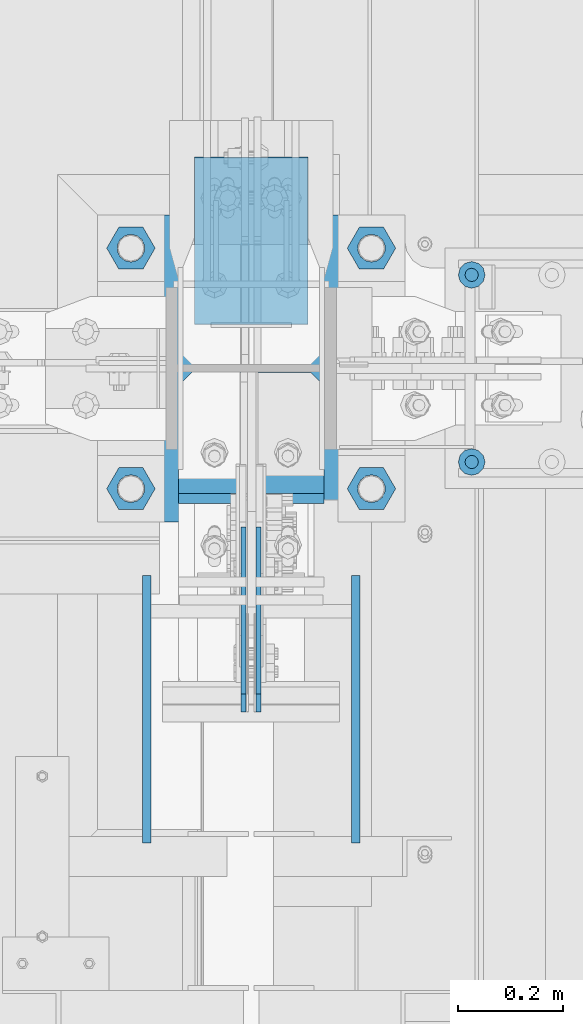
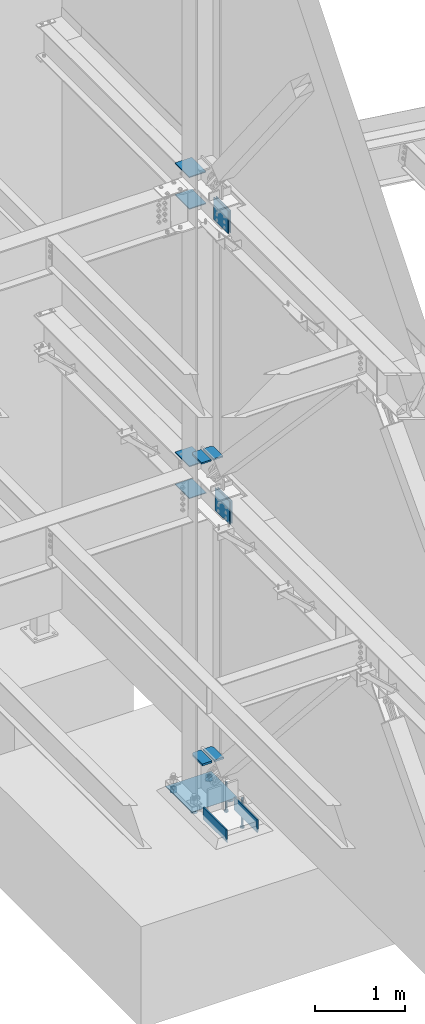
# One storey, part 897 of 1179: 21 beams, 11 elements without a shape of their own.
"""IFC2X3 building model written with IfcOpenShell, lengths in millimetres."""

from ifc_helpers import new_model, si_unit, frame, origin_with_axes, place, context, subcontext, project, spatial, faceted_brep, material, type_object, element, aggregate, save


model = new_model("IFC2X3")

# Units and contexts
model_context = context("Model", 3, precision=1e-05, world=origin_with_axes())
body_context = subcontext(model_context, "Body", "Model", "MODEL_VIEW")
ifc_project = project(units=[si_unit("LENGTHUNIT", "METRE", prefix="MILLI"), si_unit("AREAUNIT", "SQUARE_METRE"), si_unit("VOLUMEUNIT", "CUBIC_METRE"), si_unit("MASSUNIT", "GRAM", prefix="KILO"), si_unit("TIMEUNIT", "SECOND"), si_unit("PLANEANGLEUNIT", "RADIAN"), si_unit("SOLIDANGLEUNIT", "STERADIAN"), si_unit("THERMODYNAMICTEMPERATUREUNIT", "DEGREE_CELSIUS"), si_unit("LUMINOUSINTENSITYUNIT", "LUMEN")], contexts=[model_context])

# Site, building, storey
site_placement = place(None, origin_with_axes())
site = spatial("IfcSite", under=ifc_project, at=site_placement, CompositionType="ELEMENT")
building_placement = place(site_placement, origin_with_axes())
building = spatial("IfcBuilding", under=site, at=building_placement, Name="Undefined", CompositionType="ELEMENT")
storey_placement = place(building_placement, origin_with_axes())
storey = spatial("IfcBuildingStorey", under=building, at=storey_placement, Name="Undefined", CompositionType="ELEMENT", Elevation=0.0)

# Assembly, beams
assembly_1_placement = place(storey_placement, origin_with_axes())
assembly_1 = element("IfcElementAssembly", 1, at=assembly_1_placement, inside=storey, Name="COLUMN", AssemblyPlace="NOTDEFINED", PredefinedType="RIGID_FRAME")
ifc_material_1 = material(Name="STEEL/A572-GR.50")
beam_type_1 = type_object("IfcBeamType", PredefinedType="NOTDEFINED")
beam_1_placement = place(assembly_1_placement, frame((24307.8, 34475.7375, 7591.425), z_axis=(1.0, 0.0, 0.0), x_axis=(0.0, 1.0, 0.0)))
beam_1 = element("IfcBeam", 2, at=beam_1_placement, type_object=beam_type_1, material=ifc_material_1, Name="PLATE", context=body_context, shape_type="Brep", body=[
    faceted_brep([(0.0, 6.35000000000036, -107.949999999997), (0.0, 6.35000000000036, 107.949999999997), (317.5, 6.35000000000036, 107.949999999997), (317.5, 6.35000000000036, -107.949999999997), (0.0, -6.35000000000036, 107.949999999997), (317.5, -6.35000000000036, 107.949999999997), (0.0, -6.35000000000036, -107.949999999997), (317.5, -6.35000000000036, -107.949999999997)], [[[0, 1, 2, 3]], [[1, 4, 5, 2]], [[4, 6, 7, 5]], [[6, 0, 3, 7]], [[5, 7, 3, 2]], [[6, 4, 1, 0]]]),
])
beam_2_placement = place(assembly_1_placement, frame((24307.8, 34475.7375, 8020.05), z_axis=(1.0, 0.0, 0.0), x_axis=(0.0, 1.0, 0.0)))
beam_2 = element("IfcBeam", 3, at=beam_2_placement, type_object=beam_type_1, material=ifc_material_1, Name="PLATE", context=body_context, shape_type="Brep", body=[
    faceted_brep([(0.0, 6.35000000000036, -107.949999999997), (0.0, 6.35000000000036, 107.949999999997), (317.5, 6.35000000000036, 107.949999999997), (317.5, 6.35000000000036, -107.949999999997), (0.0, -6.35000000000036, 107.949999999997), (317.5, -6.35000000000036, 107.949999999997), (0.0, -6.35000000000036, -107.949999999997), (317.5, -6.35000000000036, -107.949999999997)], [[[0, 1, 2, 3]], [[1, 4, 5, 2]], [[4, 6, 7, 5]], [[6, 0, 3, 7]], [[5, 7, 3, 2]], [[6, 4, 1, 0]]]),
])
beam_3_placement = place(assembly_1_placement, frame((24307.8, 34474.94375, 3676.65), z_axis=(1.0, 0.0, 0.0), x_axis=(0.0, 1.0, 0.0)))
beam_3 = element("IfcBeam", 4, at=beam_3_placement, type_object=beam_type_1, material=ifc_material_1, Name="PLATE", context=body_context, shape_type="Brep", body=[
    faceted_brep([(0.0, 6.35000000000036, -107.949999999997), (0.0, 6.35000000000036, 107.949999999997), (317.5, 6.35000000000036, 107.949999999997), (317.5, 6.35000000000036, -107.949999999997), (0.0, -6.35000000000036, 107.949999999997), (317.5, -6.35000000000036, 107.949999999997), (0.0, -6.35000000000036, -107.949999999997), (317.5, -6.35000000000036, -107.949999999997)], [[[0, 1, 2, 3]], [[1, 4, 5, 2]], [[4, 6, 7, 5]], [[6, 0, 3, 7]], [[5, 7, 3, 2]], [[6, 4, 1, 0]]]),
])
beam_4_placement = place(assembly_1_placement, frame((24307.8, 34474.94375, 4108.45), z_axis=(1.0, 0.0, 0.0), x_axis=(0.0, 1.0, 0.0)))
beam_4 = element("IfcBeam", 5, at=beam_4_placement, type_object=beam_type_1, material=ifc_material_1, Name="PLATE", context=body_context, shape_type="Brep", body=[
    faceted_brep([(0.0, 6.35000000000036, -107.949999999997), (0.0, 6.35000000000036, 107.949999999997), (317.5, 6.35000000000036, 107.949999999997), (317.5, 6.35000000000036, -107.949999999997), (0.0, -6.35000000000036, 107.949999999997), (317.5, -6.35000000000036, 107.949999999997), (0.0, -6.35000000000036, -107.949999999997), (317.5, -6.35000000000036, -107.949999999997)], [[[0, 1, 2, 3]], [[1, 4, 5, 2]], [[4, 6, 7, 5]], [[6, 0, 3, 7]], [[5, 7, 3, 2]], [[6, 4, 1, 0]]]),
])
beam_type_2 = type_object("IfcBeamType", PredefinedType="NOTDEFINED")
beam_5_placement = place(assembly_1_placement, frame((24382.4125, 34153.8677008652, 4353.49928063271), z_axis=(1.0, 0.0, 0.0), x_axis=(0.0, 1.0, 0.0)))
beam_5 = element("IfcBeam", 6, at=beam_5_placement, type_object=beam_type_2, material=ifc_material_1, Name="PLATE", context=body_context, shape_type="Brep", body=[
    faceted_brep([(230.588549134773, 9.52499999999964, 38.0999999999985), (205.188549134771, 9.52499999999964, 63.5), (205.188549134771, -9.52499999999964, 63.5), (230.588549134773, -9.52499999999964, 38.0999999999985), (230.588549134773, 9.52499999999964, -63.5), (0.0, 9.52500000000146, -63.5), (0.0, 9.52500000000146, 63.5), (0.0, -9.52500000000146, 63.5), (0.0, -9.52500000000146, -63.5), (230.588549134773, -9.52499999999964, -63.5)], [[[0, 1, 2, 3]], [[4, 5, 6, 1, 0]], [[6, 7, 2, 1]], [[7, 8, 9, 3, 2]], [[8, 5, 4, 9]], [[9, 4, 0, 3]], [[8, 7, 6, 5]]]),
])
beam_6_placement = place(assembly_1_placement, frame((24233.1875, 34153.8677008652, 4353.49928063271), z_axis=(-1.0, 0.0, 0.0), x_axis=(0.0, 1.0, 0.0)))
beam_6 = element("IfcBeam", 7, at=beam_6_placement, type_object=beam_type_2, material=ifc_material_1, Name="PLATE", context=body_context, shape_type="Brep", body=[
    faceted_brep([(230.588549134773, 9.52499999999964, 38.0999999999985), (205.188549134771, 9.52499999999964, 63.5), (205.188549134771, -9.52499999999964, 63.5), (230.588549134773, -9.52499999999964, 38.0999999999985), (230.588549134773, 9.52499999999964, -63.5), (0.0, 9.52500000000146, -63.5), (0.0, 9.52500000000146, 63.5), (0.0, -9.52500000000146, 63.5), (0.0, -9.52500000000146, -63.5), (230.588549134773, -9.52499999999964, -63.5)], [[[0, 1, 2, 3]], [[4, 5, 6, 1, 0]], [[6, 7, 2, 1]], [[7, 8, 9, 3, 2]], [[8, 5, 4, 9]], [[9, 4, 0, 3]], [[8, 7, 6, 5]]]),
])
aggregate(assembly_1, [beam_5, beam_6, beam_1, beam_2, beam_3, beam_4])

# Assembly, beam
assembly_2_placement = place(storey_placement, origin_with_axes())
assembly_2 = element("IfcElementAssembly", 8, at=assembly_2_placement, inside=storey, Name="PLATE", AssemblyPlace="NOTDEFINED", PredefinedType="RIGID_FRAME")
beam_type_3 = type_object("IfcBeamType", PredefinedType="NOTDEFINED")
beam_7_placement = place(assembly_2_placement, frame((24293.5125, 33738.9169989339, 3892.55), z_axis=(0.0, 0.0, -1.0), x_axis=(0.0, 1.0, 0.0)))
beam_7 = element("IfcBeam", 9, at=beam_7_placement, type_object=beam_type_3, material=ifc_material_1, Name="PLATE", context=body_context, shape_type="Brep", body=[
    faceted_brep([(0.0, 4.76250000000073, -152.4), (0.0, 4.76250000000073, 152.4), (317.5, 4.76250000000073, 152.4), (317.5, 4.76250000000073, -152.4), (0.0, -4.76250000000073, 152.4), (317.5, -4.76250000000073, 152.4), (0.0, -4.76250000000073, -152.4), (317.5, -4.76250000000073, -152.4)], [[[0, 1, 2, 3]], [[1, 4, 5, 2]], [[4, 6, 7, 5]], [[6, 0, 3, 7]], [[5, 7, 3, 2]], [[6, 4, 1, 0]]]),
])
aggregate(assembly_2, [beam_7])

assembly_3_placement = place(storey_placement, origin_with_axes())
assembly_3 = element("IfcElementAssembly", 10, at=assembly_3_placement, inside=storey, Name="PLATE", AssemblyPlace="NOTDEFINED", PredefinedType="RIGID_FRAME")
beam_8_placement = place(assembly_3_placement, frame((24322.0875, 34056.4169989339, 3892.55), z_axis=(0.0, 0.0, -1.0), x_axis=(0.0, -1.0, 0.0)))
beam_8 = element("IfcBeam", 11, at=beam_8_placement, type_object=beam_type_3, material=ifc_material_1, Name="PLATE", context=body_context, shape_type="Brep", body=[
    faceted_brep([(0.0, 4.76250000000073, -152.4), (0.0, 4.76250000000073, 152.4), (317.5, 4.76250000000073, 152.4), (317.5, 4.76250000000073, -152.4), (0.0, -4.76250000000073, 152.4), (317.5, -4.76250000000073, 152.4), (0.0, -4.76250000000073, -152.4), (317.5, -4.76250000000073, -152.4)], [[[0, 1, 2, 3]], [[1, 4, 5, 2]], [[4, 6, 7, 5]], [[6, 0, 3, 7]], [[5, 7, 3, 2]], [[6, 4, 1, 0]]]),
])
aggregate(assembly_3, [beam_8])

assembly_4_placement = place(storey_placement, origin_with_axes())
assembly_4 = element("IfcElementAssembly", 12, at=assembly_4_placement, inside=storey, Name="PLATE", AssemblyPlace="NOTDEFINED", PredefinedType="RIGID_FRAME")
beam_9_placement = place(assembly_4_placement, frame((24293.5127863882, 33773.0911790882, 7804.15), z_axis=(0.0, 0.0, -1.0), x_axis=(0.0, 1.0, 0.0)))
beam_9 = element("IfcBeam", 13, at=beam_9_placement, type_object=beam_type_3, material=ifc_material_1, Name="PLATE", context=body_context, shape_type="Brep", body=[
    faceted_brep([(0.0, 4.76250000000073, -152.4), (0.0, 4.76250000000073, 152.4), (317.5, 4.76250000000073, 152.4), (317.5, 4.76250000000073, -152.4), (0.0, -4.76250000000073, 152.4), (317.5, -4.76250000000073, 152.4), (0.0, -4.76250000000073, -152.4), (317.5, -4.76250000000073, -152.4)], [[[0, 1, 2, 3]], [[1, 4, 5, 2]], [[4, 6, 7, 5]], [[6, 0, 3, 7]], [[5, 7, 3, 2]], [[6, 4, 1, 0]]]),
])
aggregate(assembly_4, [beam_9])

assembly_5_placement = place(storey_placement, origin_with_axes())
assembly_5 = element("IfcElementAssembly", 14, at=assembly_5_placement, inside=storey, Name="PLATE", AssemblyPlace="NOTDEFINED", PredefinedType="RIGID_FRAME")
beam_10_placement = place(assembly_5_placement, frame((24322.0872136118, 34090.5911790882, 7804.15), z_axis=(0.0, 0.0, -1.0), x_axis=(0.0, -1.0, 0.0)))
beam_10 = element("IfcBeam", 15, at=beam_10_placement, type_object=beam_type_3, material=ifc_material_1, Name="PLATE", context=body_context, shape_type="Brep", body=[
    faceted_brep([(0.0, 4.76250000000073, -152.4), (0.0, 4.76250000000073, 152.4), (317.5, 4.76250000000073, 152.4), (317.5, 4.76250000000073, -152.4), (0.0, -4.76250000000073, 152.4), (317.5, -4.76250000000073, 152.4), (0.0, -4.76250000000073, -152.4), (317.5, -4.76250000000073, -152.4)], [[[0, 1, 2, 3]], [[1, 4, 5, 2]], [[4, 6, 7, 5]], [[6, 0, 3, 7]], [[5, 7, 3, 2]], [[6, 4, 1, 0]]]),
])
aggregate(assembly_5, [beam_10])

assembly_6_placement = place(storey_placement, origin_with_axes())
assembly_6 = element("IfcElementAssembly", 16, at=assembly_6_placement, inside=storey, Name="PLATE", AssemblyPlace="NOTDEFINED", PredefinedType="RIGID_FRAME")
beam_type_4 = type_object("IfcBeamType", PredefinedType="NOTDEFINED")
beam_11_placement = place(assembly_6_placement, frame((24384.0, 34135.3572204195, 286.524676908997), z_axis=(1.0, 0.0, 0.0), x_axis=(0.0, 1.0, 0.0)))
beam_11 = element("IfcBeam", 17, at=beam_11_placement, type_object=beam_type_4, material=ifc_material_1, Name="PLATE", context=body_context, shape_type="Brep", body=[
    faceted_brep([(249.09902958051, 12.7, 36.5125000000007), (223.699029580508, 12.7, 61.9124999999985), (223.699029580508, -12.7, 61.9124999999985), (249.09902958051, -12.7, 36.5125000000007), (249.09902958051, 12.7, -61.9124999999985), (0.0, 12.7, -61.9124999999985), (0.0, 12.7, 61.9124999999985), (0.0, -12.7, 61.9124999999985), (0.0, -12.7, -61.9124999999985), (249.09902958051, -12.7, -61.9124999999985)], [[[0, 1, 2, 3]], [[4, 5, 6, 1, 0]], [[6, 7, 2, 1]], [[7, 8, 9, 3, 2]], [[8, 5, 4, 9]], [[9, 4, 0, 3]], [[8, 7, 6, 5]]]),
])
aggregate(assembly_6, [beam_11])

assembly_7_placement = place(storey_placement, origin_with_axes())
assembly_7 = element("IfcElementAssembly", 18, at=assembly_7_placement, inside=storey, Name="PLATE", AssemblyPlace="NOTDEFINED", PredefinedType="RIGID_FRAME")
beam_12_placement = place(assembly_7_placement, frame((24231.6, 34135.3572204195, 286.524676908997), z_axis=(-1.0, 0.0, 0.0), x_axis=(0.0, 1.0, 0.0)))
beam_12 = element("IfcBeam", 19, at=beam_12_placement, type_object=beam_type_4, material=ifc_material_1, Name="PLATE", context=body_context, shape_type="Brep", body=[
    faceted_brep([(249.09902958051, 12.7, 36.5125000000007), (223.699029580508, 12.7, 61.9124999999985), (223.699029580508, -12.7, 61.9124999999985), (249.09902958051, -12.7, 36.5125000000007), (249.09902958051, 12.7, -61.9124999999985), (0.0, 12.7, -61.9124999999985), (0.0, 12.7, 61.9124999999985), (0.0, -12.7, 61.9124999999985), (0.0, -12.7, -61.9124999999985), (249.09902958051, -12.7, -61.9124999999985)], [[[0, 1, 2, 3]], [[4, 5, 6, 1, 0]], [[6, 7, 2, 1]], [[7, 8, 9, 3, 2]], [[8, 5, 4, 9]], [[9, 4, 0, 3]], [[8, 7, 6, 5]]]),
])
aggregate(assembly_7, [beam_12])

# Assembly, beams
assembly_8_placement = place(storey_placement, origin_with_axes())
assembly_8 = element("IfcElementAssembly", 20, at=assembly_8_placement, inside=storey, Name="TEMPLATE", AssemblyPlace="NOTDEFINED", PredefinedType="RIGID_FRAME")
ifc_material_2 = material(Name="STEEL/A36")
beam_type_5 = type_object("IfcBeamType", PredefinedType="NOTDEFINED")
beam_13_placement = place(assembly_8_placement, frame((24307.8000236655, 34099.4999957541, -277.8125), z_axis=(-1.0, 0.0, 0.0), x_axis=(0.0, 1.0, 0.0)))
beam_13 = element("IfcBeam", 21, at=beam_13_placement, type_object=beam_type_5, material=ifc_material_2, Name="TEMPLATE", context=body_context, shape_type="Brep", body=[
    faceted_brep([(0.0, 1.58749999999998, -292.099999999999), (0.0, 1.58749999999998, 292.099999999999), (584.199496459973, 1.58749999999998, 292.099999999999), (584.199496459973, 1.58749999999998, -292.099999999999), (0.0, -1.58749999999998, 292.099999999999), (584.199496459973, -1.58749999999998, 292.099999999999), (0.0, -1.58749999999998, -292.099999999999), (584.199496459973, -1.58749999999998, -292.099999999999)], [[[0, 1, 2, 3]], [[1, 4, 5, 2]], [[4, 6, 7, 5]], [[6, 0, 3, 7]], [[5, 7, 3, 2]], [[6, 4, 1, 0]]]),
])
beam_type_6 = type_object("IfcBeamType", Name="2_HEAVY_HEX_NUT", PredefinedType="NOTDEFINED")
beam_14_placement = place(assembly_8_placement, frame((24079.2, 34163.0, -279.4), z_axis=(0.0, -1.0, 0.0), x_axis=(0.0, 0.0, -1.0)))
beam_14 = element("IfcBeam", 22, at=beam_14_placement, type_object=beam_type_6, material=ifc_material_2, Name="NUT", ObjectType="2_HEAVY_HEX_NUT", context=body_context, shape_type="Brep", body=[
    faceted_brep([(0.0, -46.0369987487793, 9.09494701772928e-13), (0.0, -23.0184993743896, -39.869213104248), (50.7999999999993, -23.0184993743896, -39.869213104248), (50.7999999999993, -46.0369987487793, 9.09494701772928e-13), (0.0, 23.0184993743896, -39.869213104248), (50.7999999999993, 23.0184993743896, -39.869213104248), (0.0, 46.0369987487793, -9.09494701772928e-13), (50.7999999999993, 46.0369987487793, -9.09494701772928e-13), (0.0, 23.0184993743896, 39.869213104248), (50.7999999999993, 23.0184993743896, 39.869213104248), (0.0, -23.0184993743896, 39.869213104248), (50.7999999999993, -23.0184993743896, 39.869213104248), (0.0, 0.0, 26.1940002441406), (0.0, 11.3650617044477, 23.5999013092769), (50.7999999999993, 11.3650617044477, 23.5999013092769), (50.7999999999993, 0.0, 26.1940002441406), (0.0, 20.4791109456419, 16.3316083006703), (50.7999999999993, 20.4791109456419, 16.3316083006703), (0.0, 25.5370200498364, 5.82867859874477), (50.7999999999993, 25.5370200498364, 5.82867859874477), (0.0, 25.5370200498364, -5.82867859874477), (50.7999999999993, 25.5370200498364, -5.82867859874477), (0.0, 20.4791109456419, -16.3316083006703), (50.7999999999993, 20.4791109456419, -16.3316083006703), (0.0, 11.365061704455, -23.5999013092769), (50.7999999999993, 11.365061704455, -23.5999013092769), (0.0, 0.0, -26.1940002441406), (50.7999999999993, 0.0, -26.1940002441406), (0.0, -11.3650617044477, -23.5999013092769), (50.7999999999993, -11.3650617044477, -23.5999013092769), (0.0, -20.4791109456419, -16.3316083006703), (50.7999999999993, -20.4791109456419, -16.3316083006703), (0.0, -25.5370200498364, -5.82867859874477), (50.7999999999993, -25.5370200498364, -5.82867859874477), (0.0, -25.5370200498364, 5.82867859874477), (50.7999999999993, -25.5370200498364, 5.82867859874477), (0.0, -20.4791109456419, 16.3316083006703), (50.7999999999993, -20.4791109456419, 16.3316083006703), (0.0, -11.365061704455, 23.5999013092769), (50.7999999999993, -11.365061704455, 23.5999013092769)], [[[0, 1, 2, 3]], [[1, 4, 5, 2]], [[4, 6, 7, 5]], [[6, 8, 9, 7]], [[8, 10, 11, 9]], [[10, 0, 3, 11]], [[12, 13, 14, 15]], [[13, 16, 17, 14]], [[16, 18, 19, 17]], [[18, 20, 21, 19]], [[20, 22, 23, 21]], [[22, 24, 25, 23]], [[24, 26, 27, 25]], [[26, 28, 29, 27]], [[28, 30, 31, 29]], [[30, 32, 33, 31]], [[32, 34, 35, 33]], [[34, 36, 37, 35]], [[36, 38, 39, 37]], [[38, 12, 15, 39]], [[5, 7, 9, 11, 3, 2], [17, 19, 21, 23, 25, 27, 29, 31, 33, 35, 37, 39, 15, 14]], [[10, 8, 6, 4, 1, 0], [38, 36, 34, 32, 30, 28, 26, 24, 22, 20, 18, 16, 13, 12]]]),
])
beam_15_placement = place(assembly_8_placement, frame((24536.4, 34163.0, -279.4), z_axis=(0.0, 1.0, 0.0), x_axis=(0.0, 0.0, -1.0)))
beam_15 = element("IfcBeam", 23, at=beam_15_placement, type_object=beam_type_6, material=ifc_material_2, Name="NUT", ObjectType="2_HEAVY_HEX_NUT", context=body_context, shape_type="Brep", body=[
    faceted_brep([(0.0, -46.0369987487793, 9.09494701772928e-13), (0.0, -23.0184993743896, -39.869213104248), (50.7999999999993, -23.0184993743896, -39.869213104248), (50.7999999999993, -46.0369987487793, 9.09494701772928e-13), (0.0, 23.0184993743896, -39.869213104248), (50.7999999999993, 23.0184993743896, -39.869213104248), (0.0, 46.0369987487793, -9.09494701772928e-13), (50.7999999999993, 46.0369987487793, -9.09494701772928e-13), (0.0, 23.0184993743896, 39.869213104248), (50.7999999999993, 23.0184993743896, 39.869213104248), (0.0, -23.0184993743896, 39.869213104248), (50.7999999999993, -23.0184993743896, 39.869213104248), (0.0, 0.0, 26.1940002441406), (0.0, 11.3650617044477, 23.5999013092769), (50.7999999999993, 11.3650617044477, 23.5999013092769), (50.7999999999993, 0.0, 26.1940002441406), (0.0, 20.4791109456419, 16.3316083006703), (50.7999999999993, 20.4791109456419, 16.3316083006703), (0.0, 25.5370200498364, 5.82867859874477), (50.7999999999993, 25.5370200498364, 5.82867859874477), (0.0, 25.5370200498364, -5.82867859874477), (50.7999999999993, 25.5370200498364, -5.82867859874477), (0.0, 20.4791109456419, -16.3316083006703), (50.7999999999993, 20.4791109456419, -16.3316083006703), (0.0, 11.365061704455, -23.5999013092769), (50.7999999999993, 11.365061704455, -23.5999013092769), (0.0, 0.0, -26.1940002441406), (50.7999999999993, 0.0, -26.1940002441406), (0.0, -11.3650617044477, -23.5999013092769), (50.7999999999993, -11.3650617044477, -23.5999013092769), (0.0, -20.4791109456419, -16.3316083006703), (50.7999999999993, -20.4791109456419, -16.3316083006703), (0.0, -25.5370200498364, -5.82867859874477), (50.7999999999993, -25.5370200498364, -5.82867859874477), (0.0, -25.5370200498364, 5.82867859874477), (50.7999999999993, -25.5370200498364, 5.82867859874477), (0.0, -20.4791109456419, 16.3316083006703), (50.7999999999993, -20.4791109456419, 16.3316083006703), (0.0, -11.365061704455, 23.5999013092769), (50.7999999999993, -11.365061704455, 23.5999013092769)], [[[0, 1, 2, 3]], [[1, 4, 5, 2]], [[4, 6, 7, 5]], [[6, 8, 9, 7]], [[8, 10, 11, 9]], [[10, 0, 3, 11]], [[12, 13, 14, 15]], [[13, 16, 17, 14]], [[16, 18, 19, 17]], [[18, 20, 21, 19]], [[20, 22, 23, 21]], [[22, 24, 25, 23]], [[24, 26, 27, 25]], [[26, 28, 29, 27]], [[28, 30, 31, 29]], [[30, 32, 33, 31]], [[32, 34, 35, 33]], [[34, 36, 37, 35]], [[36, 38, 39, 37]], [[38, 12, 15, 39]], [[5, 7, 9, 11, 3, 2], [17, 19, 21, 23, 25, 27, 29, 31, 33, 35, 37, 39, 15, 14]], [[10, 8, 6, 4, 1, 0], [38, 36, 34, 32, 30, 28, 26, 24, 22, 20, 18, 16, 13, 12]]]),
])
beam_16_placement = place(assembly_8_placement, frame((24079.2, 34620.2, -279.4), z_axis=(0.0, -1.0, 0.0), x_axis=(0.0, 0.0, -1.0)))
beam_16 = element("IfcBeam", 24, at=beam_16_placement, type_object=beam_type_6, material=ifc_material_2, Name="NUT", ObjectType="2_HEAVY_HEX_NUT", context=body_context, shape_type="Brep", body=[
    faceted_brep([(0.0, -46.0369987487793, 9.09494701772928e-13), (0.0, -23.0184993743896, -39.869213104248), (50.7999999999993, -23.0184993743896, -39.869213104248), (50.7999999999993, -46.0369987487793, 9.09494701772928e-13), (0.0, 23.0184993743896, -39.869213104248), (50.7999999999993, 23.0184993743896, -39.869213104248), (0.0, 46.0369987487793, -9.09494701772928e-13), (50.7999999999993, 46.0369987487793, -9.09494701772928e-13), (0.0, 23.0184993743896, 39.869213104248), (50.7999999999993, 23.0184993743896, 39.869213104248), (0.0, -23.0184993743896, 39.869213104248), (50.7999999999993, -23.0184993743896, 39.869213104248), (0.0, 0.0, 26.1940002441406), (0.0, 11.3650617044477, 23.5999013092769), (50.7999999999993, 11.3650617044477, 23.5999013092769), (50.7999999999993, 0.0, 26.1940002441406), (0.0, 20.4791109456419, 16.3316083006703), (50.7999999999993, 20.4791109456419, 16.3316083006703), (0.0, 25.5370200498364, 5.82867859874477), (50.7999999999993, 25.5370200498364, 5.82867859874477), (0.0, 25.5370200498364, -5.82867859874477), (50.7999999999993, 25.5370200498364, -5.82867859874477), (0.0, 20.4791109456419, -16.3316083006703), (50.7999999999993, 20.4791109456419, -16.3316083006703), (0.0, 11.365061704455, -23.5999013092769), (50.7999999999993, 11.365061704455, -23.5999013092769), (0.0, 0.0, -26.1940002441406), (50.7999999999993, 0.0, -26.1940002441406), (0.0, -11.3650617044477, -23.5999013092769), (50.7999999999993, -11.3650617044477, -23.5999013092769), (0.0, -20.4791109456419, -16.3316083006703), (50.7999999999993, -20.4791109456419, -16.3316083006703), (0.0, -25.5370200498364, -5.82867859874477), (50.7999999999993, -25.5370200498364, -5.82867859874477), (0.0, -25.5370200498364, 5.82867859874477), (50.7999999999993, -25.5370200498364, 5.82867859874477), (0.0, -20.4791109456419, 16.3316083006703), (50.7999999999993, -20.4791109456419, 16.3316083006703), (0.0, -11.365061704455, 23.5999013092769), (50.7999999999993, -11.365061704455, 23.5999013092769)], [[[0, 1, 2, 3]], [[1, 4, 5, 2]], [[4, 6, 7, 5]], [[6, 8, 9, 7]], [[8, 10, 11, 9]], [[10, 0, 3, 11]], [[12, 13, 14, 15]], [[13, 16, 17, 14]], [[16, 18, 19, 17]], [[18, 20, 21, 19]], [[20, 22, 23, 21]], [[22, 24, 25, 23]], [[24, 26, 27, 25]], [[26, 28, 29, 27]], [[28, 30, 31, 29]], [[30, 32, 33, 31]], [[32, 34, 35, 33]], [[34, 36, 37, 35]], [[36, 38, 39, 37]], [[38, 12, 15, 39]], [[5, 7, 9, 11, 3, 2], [17, 19, 21, 23, 25, 27, 29, 31, 33, 35, 37, 39, 15, 14]], [[10, 8, 6, 4, 1, 0], [38, 36, 34, 32, 30, 28, 26, 24, 22, 20, 18, 16, 13, 12]]]),
])
beam_17_placement = place(assembly_8_placement, frame((24536.4, 34620.2, -279.4), z_axis=(0.0, 1.0, 0.0), x_axis=(0.0, 0.0, -1.0)))
beam_17 = element("IfcBeam", 25, at=beam_17_placement, type_object=beam_type_6, material=ifc_material_2, Name="NUT", ObjectType="2_HEAVY_HEX_NUT", context=body_context, shape_type="Brep", body=[
    faceted_brep([(0.0, -46.0369987487793, 9.09494701772928e-13), (0.0, -23.0184993743896, -39.869213104248), (50.7999999999993, -23.0184993743896, -39.869213104248), (50.7999999999993, -46.0369987487793, 9.09494701772928e-13), (0.0, 23.0184993743896, -39.869213104248), (50.7999999999993, 23.0184993743896, -39.869213104248), (0.0, 46.0369987487793, -9.09494701772928e-13), (50.7999999999993, 46.0369987487793, -9.09494701772928e-13), (0.0, 23.0184993743896, 39.869213104248), (50.7999999999993, 23.0184993743896, 39.869213104248), (0.0, -23.0184993743896, 39.869213104248), (50.7999999999993, -23.0184993743896, 39.869213104248), (0.0, 0.0, 26.1940002441406), (0.0, 11.3650617044477, 23.5999013092769), (50.7999999999993, 11.3650617044477, 23.5999013092769), (50.7999999999993, 0.0, 26.1940002441406), (0.0, 20.4791109456419, 16.3316083006703), (50.7999999999993, 20.4791109456419, 16.3316083006703), (0.0, 25.5370200498364, 5.82867859874477), (50.7999999999993, 25.5370200498364, 5.82867859874477), (0.0, 25.5370200498364, -5.82867859874477), (50.7999999999993, 25.5370200498364, -5.82867859874477), (0.0, 20.4791109456419, -16.3316083006703), (50.7999999999993, 20.4791109456419, -16.3316083006703), (0.0, 11.365061704455, -23.5999013092769), (50.7999999999993, 11.365061704455, -23.5999013092769), (0.0, 0.0, -26.1940002441406), (50.7999999999993, 0.0, -26.1940002441406), (0.0, -11.3650617044477, -23.5999013092769), (50.7999999999993, -11.3650617044477, -23.5999013092769), (0.0, -20.4791109456419, -16.3316083006703), (50.7999999999993, -20.4791109456419, -16.3316083006703), (0.0, -25.5370200498364, -5.82867859874477), (50.7999999999993, -25.5370200498364, -5.82867859874477), (0.0, -25.5370200498364, 5.82867859874477), (50.7999999999993, -25.5370200498364, 5.82867859874477), (0.0, -20.4791109456419, 16.3316083006703), (50.7999999999993, -20.4791109456419, 16.3316083006703), (0.0, -11.365061704455, 23.5999013092769), (50.7999999999993, -11.365061704455, 23.5999013092769)], [[[0, 1, 2, 3]], [[1, 4, 5, 2]], [[4, 6, 7, 5]], [[6, 8, 9, 7]], [[8, 10, 11, 9]], [[10, 0, 3, 11]], [[12, 13, 14, 15]], [[13, 16, 17, 14]], [[16, 18, 19, 17]], [[18, 20, 21, 19]], [[20, 22, 23, 21]], [[22, 24, 25, 23]], [[24, 26, 27, 25]], [[26, 28, 29, 27]], [[28, 30, 31, 29]], [[30, 32, 33, 31]], [[32, 34, 35, 33]], [[34, 36, 37, 35]], [[36, 38, 39, 37]], [[38, 12, 15, 39]], [[5, 7, 9, 11, 3, 2], [17, 19, 21, 23, 25, 27, 29, 31, 33, 35, 37, 39, 15, 14]], [[10, 8, 6, 4, 1, 0], [38, 36, 34, 32, 30, 28, 26, 24, 22, 20, 18, 16, 13, 12]]]),
])
aggregate(assembly_8, [beam_13, beam_14, beam_15, beam_16, beam_17])

# Assembly, beam
assembly_9_placement = place(storey_placement, origin_with_axes())
assembly_9 = element("IfcElementAssembly", 26, at=assembly_9_placement, inside=storey, Name="PLATE", AssemblyPlace="NOTDEFINED", PredefinedType="RIGID_FRAME")
beam_type_7 = type_object("IfcBeamType", PredefinedType="NOTDEFINED")
beam_18_placement = place(assembly_9_placement, frame((24109.362535095, 33489.89899292, -266.699999999998), z_axis=(0.0, 0.0, 1.0), x_axis=(0.0, 1.0, 0.0)))
beam_18 = element("IfcBeam", 27, at=beam_18_placement, type_object=beam_type_7, material=ifc_material_1, Name="PLATE", context=body_context, shape_type="Brep", body=[
    faceted_brep([(0.0, -7.9375, -88.9), (0.0, 7.9375, -73.025), (508.0, 7.9375, -73.025), (508.0, -7.9375, -88.9), (0.0, 7.9375, 88.9), (508.0, 7.9375, 88.9), (0.0, -7.9375, 88.9), (508.0, -7.9375, 88.9)], [[[0, 1, 2, 3]], [[4, 5, 2, 1]], [[4, 6, 7, 5]], [[6, 0, 3, 7]], [[5, 7, 3, 2]], [[6, 4, 1, 0]]]),
])
aggregate(assembly_9, [beam_18])

assembly_10_placement = place(storey_placement, origin_with_axes())
assembly_10 = element("IfcElementAssembly", 28, at=assembly_10_placement, inside=storey, Name="PLATE", AssemblyPlace="NOTDEFINED", PredefinedType="RIGID_FRAME")
beam_19_placement = place(assembly_10_placement, frame((24506.2374379058, 33489.89899292, -266.699999999998), z_axis=(0.0, 0.0, 1.0), x_axis=(0.0, 1.0, 0.0)))
beam_19 = element("IfcBeam", 29, at=beam_19_placement, type_object=beam_type_7, material=ifc_material_1, Name="PLATE", context=body_context, shape_type="Brep", body=[
    faceted_brep([(508.0, 7.9375, -88.9), (508.0, -7.9375, -73.025), (0.0, -7.9375, -73.025), (0.0, 7.9375, -88.9), (0.0, 7.9375, 88.9), (508.0, 7.9375, 88.9), (0.0, -7.9375, 88.9), (508.0, -7.9375, 88.9)], [[[0, 1, 2, 3]], [[3, 4, 5, 0]], [[4, 6, 7, 5]], [[7, 6, 2, 1]], [[5, 7, 1, 0]], [[6, 4, 3, 2]]]),
])
aggregate(assembly_10, [beam_19])

# Assembly, beams
assembly_11_placement = place(storey_placement, origin_with_axes())
assembly_11 = element("IfcElementAssembly", 30, at=assembly_11_placement, inside=storey, Name="EMBED_PLATE", AssemblyPlace="NOTDEFINED", PredefinedType="RIGID_FRAME")
ifc_material_3 = material(Name="STEEL/A108")
beam_type_8 = type_object("IfcBeamType", Name="STUD_1-DIA", PredefinedType="NOTDEFINED")
beam_20_placement = place(assembly_11_placement, frame((24726.9, 34569.4, -393.700006103516), z_axis=(1.0, 0.0, 0.0), x_axis=(0.0, 0.0, -1.0)))
beam_20 = element("IfcBeam", 31, at=beam_20_placement, type_object=beam_type_8, material=ifc_material_3, Name="STUD", ObjectType="STUD_1-DIA", context=body_context, shape_type="Brep", body=[
    faceted_brep([(0.0, -12.7, 0.0), (0.0, -11.0, -6.34999990463257), (382.016, -11.0, -6.34999990463257), (382.016, -12.6999998092651, 0.0), (0.0, -6.34999990463257, -11.0), (382.016, -6.34999990463257, -11.0), (0.0, 0.0, -12.6999998092651), (382.016, 0.0, -12.6999998092651), (0.0, 6.34999990463257, -11.0), (382.016, 6.34999990463257, -11.0), (0.0, 11.0, -6.34999990463257), (382.016, 11.0, -6.34999990463257), (0.0, 12.7, 0.0), (382.016, 12.6999998092651, 0.0), (0.0, 11.0, 6.34999990463257), (382.016, 11.0, 6.34999990463257), (0.0, 6.34999990463257, 11.0), (382.016, 6.34999990463257, 11.0), (0.0, 0.0, 12.6999998092651), (382.016, 0.0, 12.6999998092651), (0.0, -6.34999990463257, 11.0), (382.016, -6.34999990463257, 11.0), (0.0, -11.0, 6.34999990463257), (382.016, -11.0, 6.34999990463257), (386.08, -22.0, -12.6999998092651), (386.08, -25.3999996185303, 0.0), (386.08, -12.6999998092651, -22.0), (386.08, 0.0, -25.3999996185303), (386.08, 12.6999998092651, -22.0), (386.08, 22.0, -12.6999998092651), (386.08, 25.3999996185303, 0.0), (386.08, 22.0, 12.6999998092651), (386.08, 12.6999998092651, 22.0), (386.08, 0.0, 25.3999996185303), (386.08, -12.6999998092651, 22.0), (386.08, -22.0, 12.6999998092651), (406.4, -22.0, -12.6999998092651), (406.4, -25.3999996185303, 0.0), (406.4, -12.6999998092651, -22.0), (406.4, 0.0, -25.3999996185303), (406.4, 12.6999998092651, -22.0), (406.4, 22.0, -12.6999998092651), (406.4, 25.3999996185303, 0.0), (406.4, 22.0, 12.6999998092651), (406.4, 12.6999998092651, 22.0), (406.4, 0.0, 25.3999996185303), (406.4, -12.6999998092651, 22.0), (406.4, -22.0, 12.6999998092651)], [[[0, 1, 2, 3]], [[1, 4, 5, 2]], [[4, 6, 7, 5]], [[6, 8, 9, 7]], [[8, 10, 11, 9]], [[10, 12, 13, 11]], [[12, 14, 15, 13]], [[14, 16, 17, 15]], [[16, 18, 19, 17]], [[18, 20, 21, 19]], [[20, 22, 23, 21]], [[22, 0, 3, 23]], [[22, 20, 18, 16, 14, 12, 10, 8, 6, 4, 1, 0]], [[3, 2, 24, 25]], [[2, 5, 26, 24]], [[5, 7, 27, 26]], [[7, 9, 28, 27]], [[9, 11, 29, 28]], [[11, 13, 30, 29]], [[13, 15, 31, 30]], [[15, 17, 32, 31]], [[17, 19, 33, 32]], [[19, 21, 34, 33]], [[21, 23, 35, 34]], [[23, 3, 25, 35]], [[25, 24, 36, 37]], [[24, 26, 38, 36]], [[26, 27, 39, 38]], [[27, 28, 40, 39]], [[28, 29, 41, 40]], [[29, 30, 42, 41]], [[30, 31, 43, 42]], [[31, 32, 44, 43]], [[32, 33, 45, 44]], [[33, 34, 46, 45]], [[34, 35, 47, 46]], [[35, 25, 37, 47]], [[38, 39, 40, 41, 42, 43, 44, 45, 46, 47, 37, 36]]]),
])
beam_21_placement = place(assembly_11_placement, frame((24726.9, 34213.8, -393.700006103516), z_axis=(1.0, 0.0, 0.0), x_axis=(0.0, 0.0, -1.0)))
beam_21 = element("IfcBeam", 32, at=beam_21_placement, type_object=beam_type_8, material=ifc_material_3, Name="STUD", ObjectType="STUD_1-DIA", context=body_context, shape_type="Brep", body=[
    faceted_brep([(0.0, -12.7, 0.0), (0.0, -11.0, -6.34999990463257), (382.016, -11.0, -6.34999990463257), (382.016, -12.6999998092651, 0.0), (0.0, -6.34999990463257, -11.0), (382.016, -6.34999990463257, -11.0), (0.0, 0.0, -12.6999998092651), (382.016, 0.0, -12.6999998092651), (0.0, 6.34999990463257, -11.0), (382.016, 6.34999990463257, -11.0), (0.0, 11.0, -6.34999990463257), (382.016, 11.0, -6.34999990463257), (0.0, 12.7, 0.0), (382.016, 12.6999998092651, 0.0), (0.0, 11.0, 6.34999990463257), (382.016, 11.0, 6.34999990463257), (0.0, 6.34999990463257, 11.0), (382.016, 6.34999990463257, 11.0), (0.0, 0.0, 12.6999998092651), (382.016, 0.0, 12.6999998092651), (0.0, -6.34999990463257, 11.0), (382.016, -6.34999990463257, 11.0), (0.0, -11.0, 6.34999990463257), (382.016, -11.0, 6.34999990463257), (386.08, -22.0, -12.6999998092651), (386.08, -25.3999996185303, 0.0), (386.08, -12.6999998092651, -22.0), (386.08, 0.0, -25.3999996185303), (386.08, 12.6999998092651, -22.0), (386.08, 22.0, -12.6999998092651), (386.08, 25.3999996185303, 0.0), (386.08, 22.0, 12.6999998092651), (386.08, 12.6999998092651, 22.0), (386.08, 0.0, 25.3999996185303), (386.08, -12.6999998092651, 22.0), (386.08, -22.0, 12.6999998092651), (406.4, -22.0, -12.6999998092651), (406.4, -25.3999996185303, 0.0), (406.4, -12.6999998092651, -22.0), (406.4, 0.0, -25.3999996185303), (406.4, 12.6999998092651, -22.0), (406.4, 22.0, -12.6999998092651), (406.4, 25.3999996185303, 0.0), (406.4, 22.0, 12.6999998092651), (406.4, 12.6999998092651, 22.0), (406.4, 0.0, 25.3999996185303), (406.4, -12.6999998092651, 22.0), (406.4, -22.0, 12.6999998092651)], [[[0, 1, 2, 3]], [[1, 4, 5, 2]], [[4, 6, 7, 5]], [[6, 8, 9, 7]], [[8, 10, 11, 9]], [[10, 12, 13, 11]], [[12, 14, 15, 13]], [[14, 16, 17, 15]], [[16, 18, 19, 17]], [[18, 20, 21, 19]], [[20, 22, 23, 21]], [[22, 0, 3, 23]], [[22, 20, 18, 16, 14, 12, 10, 8, 6, 4, 1, 0]], [[3, 2, 24, 25]], [[2, 5, 26, 24]], [[5, 7, 27, 26]], [[7, 9, 28, 27]], [[9, 11, 29, 28]], [[11, 13, 30, 29]], [[13, 15, 31, 30]], [[15, 17, 32, 31]], [[17, 19, 33, 32]], [[19, 21, 34, 33]], [[21, 23, 35, 34]], [[23, 3, 25, 35]], [[25, 24, 36, 37]], [[24, 26, 38, 36]], [[26, 27, 39, 38]], [[27, 28, 40, 39]], [[28, 29, 41, 40]], [[29, 30, 42, 41]], [[30, 31, 43, 42]], [[31, 32, 44, 43]], [[32, 33, 45, 44]], [[33, 34, 46, 45]], [[34, 35, 47, 46]], [[35, 25, 37, 47]], [[38, 39, 40, 41, 42, 43, 44, 45, 46, 47, 37, 36]]]),
])
aggregate(assembly_11, [beam_20, beam_21])

save(model, "model.ifc")
